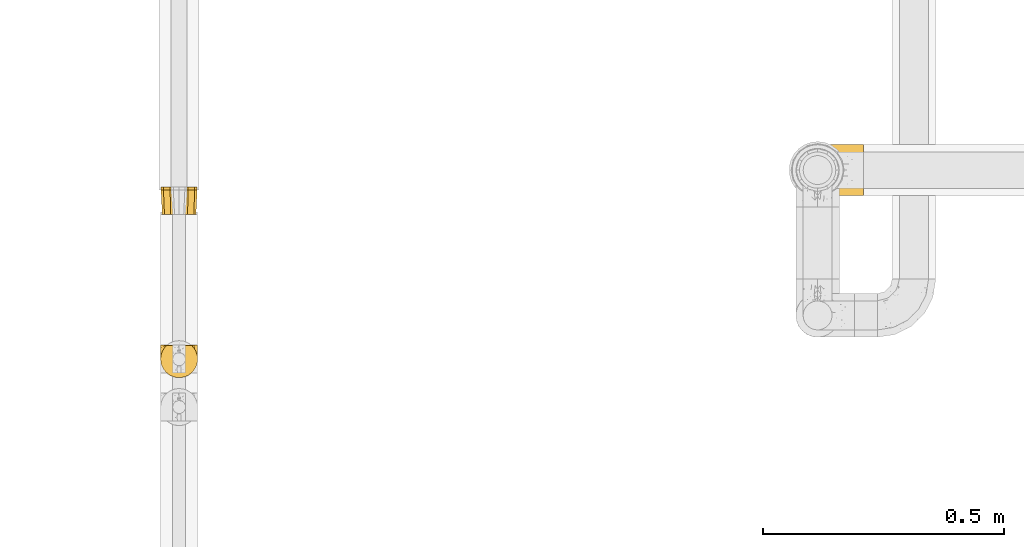
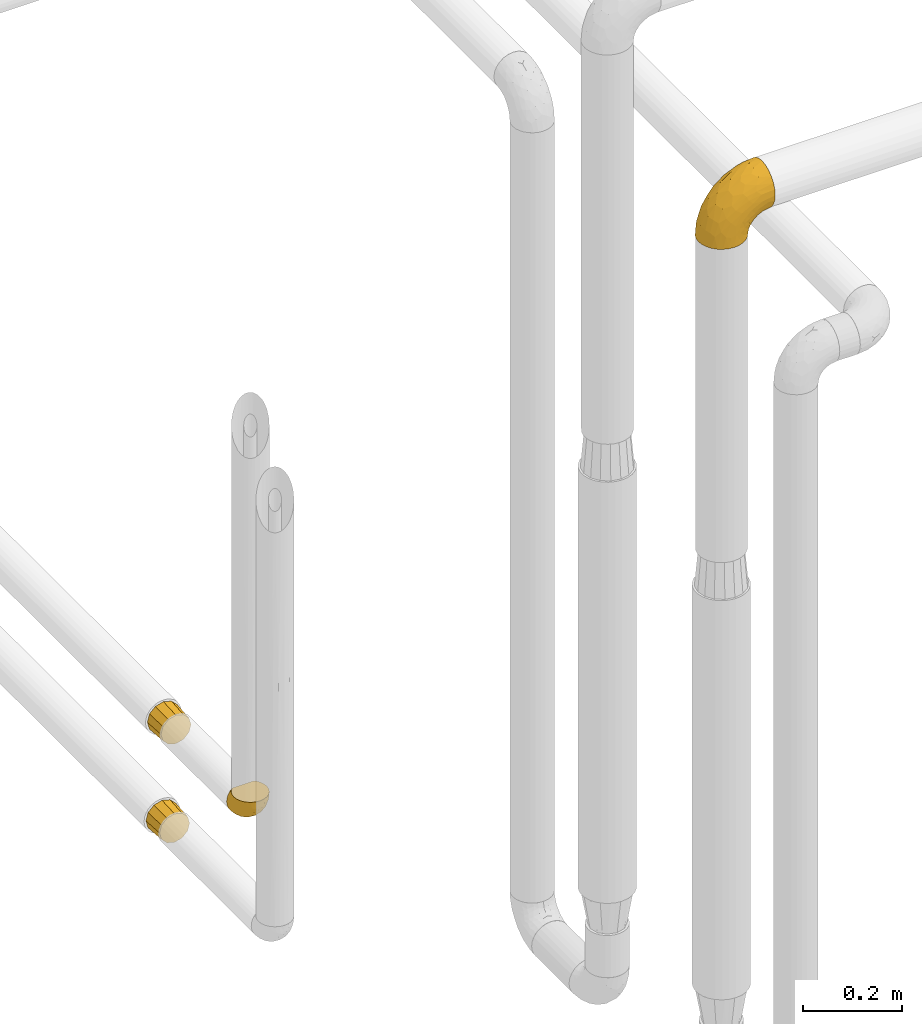
# One storey, part 106 of 827: 4 coverings.
"""IFC2X3 building model written with IfcOpenShell, lengths in millimetres."""

from ifc_helpers import new_model, entity, si_unit, converted_unit, derived_unit, direction, frame, origin, place, context, subcontext, project, spatial, faceted_brep, element, save


model = new_model("IFC2X3")

# Units and contexts
model_context = context("Model", 3, precision=0.01, world=origin(), true_north=direction((6.12303176911189e-17, 1.0)))
body_context = subcontext(model_context, "Body", "Model", "MODEL_VIEW")
ifc_project = project(units=[si_unit("LENGTHUNIT", "METRE", prefix="MILLI"), si_unit("AREAUNIT", "SQUARE_METRE"), si_unit("VOLUMEUNIT", "CUBIC_METRE"), converted_unit("PLANEANGLEUNIT", "DEGREE", entity("IfcRatioMeasure", 0.0174532925199433), si_unit("PLANEANGLEUNIT", "RADIAN"), dimensions=[0, 0, 0, 0, 0, 0, 0]), si_unit("MASSUNIT", "GRAM", prefix="KILO"), derived_unit("MASSDENSITYUNIT", [(si_unit("MASSUNIT", "GRAM", prefix="KILO"), 1), (si_unit("LENGTHUNIT", "METRE"), -3)]), derived_unit("MOMENTOFINERTIAUNIT", [(si_unit("LENGTHUNIT", "METRE"), 4)]), si_unit("TIMEUNIT", "SECOND"), si_unit("FREQUENCYUNIT", "HERTZ"), si_unit("THERMODYNAMICTEMPERATUREUNIT", "DEGREE_CELSIUS"), derived_unit("THERMALTRANSMITTANCEUNIT", [(si_unit("MASSUNIT", "GRAM", prefix="KILO"), 1), (si_unit("THERMODYNAMICTEMPERATUREUNIT", "KELVIN"), -1), (si_unit("TIMEUNIT", "SECOND"), -3)]), derived_unit("VOLUMETRICFLOWRATEUNIT", [(si_unit("LENGTHUNIT", "METRE"), 3), (si_unit("TIMEUNIT", "SECOND"), -1)]), derived_unit("MASSFLOWRATEUNIT", [(si_unit("MASSUNIT", "GRAM", prefix="KILO"), 1), (si_unit("TIMEUNIT", "SECOND"), -1)]), derived_unit("ROTATIONALFREQUENCYUNIT", [(si_unit("TIMEUNIT", "SECOND"), -1)]), si_unit("ELECTRICCURRENTUNIT", "AMPERE"), si_unit("ELECTRICVOLTAGEUNIT", "VOLT"), si_unit("POWERUNIT", "WATT"), si_unit("FORCEUNIT", "NEWTON", prefix="KILO"), si_unit("ILLUMINANCEUNIT", "LUX"), si_unit("LUMINOUSFLUXUNIT", "LUMEN"), si_unit("LUMINOUSINTENSITYUNIT", "CANDELA"), derived_unit("USERDEFINED", [(si_unit("MASSUNIT", "GRAM", prefix="KILO"), -1), (si_unit("LENGTHUNIT", "METRE"), -2), (si_unit("TIMEUNIT", "SECOND"), 3), (si_unit("LUMINOUSFLUXUNIT", "LUMEN"), 1)]), derived_unit("LINEARVELOCITYUNIT", [(si_unit("LENGTHUNIT", "METRE"), 1), (si_unit("TIMEUNIT", "SECOND"), -1)]), si_unit("PRESSUREUNIT", "PASCAL"), derived_unit("USERDEFINED", [(si_unit("LENGTHUNIT", "METRE"), -2), (si_unit("MASSUNIT", "GRAM", prefix="KILO"), 1), (si_unit("TIMEUNIT", "SECOND"), -2)]), derived_unit("LINEARFORCEUNIT", [(si_unit("MASSUNIT", "GRAM", prefix="KILO"), 1), (si_unit("LENGTHUNIT", "METRE"), 1), (si_unit("TIMEUNIT", "SECOND"), -2), (si_unit("LENGTHUNIT", "METRE"), -1)]), derived_unit("PLANARFORCEUNIT", [(si_unit("MASSUNIT", "GRAM", prefix="KILO"), 1), (si_unit("LENGTHUNIT", "METRE"), 1), (si_unit("TIMEUNIT", "SECOND"), -2), (si_unit("LENGTHUNIT", "METRE"), -2)])], contexts=[model_context])

# Site, building, storey
site_placement = place(None, origin())
site = spatial("IfcSite", under=ifc_project, at=site_placement, CompositionType="ELEMENT")
building_placement = place(site_placement, origin())
building = spatial("IfcBuilding", under=site, at=building_placement, CompositionType="ELEMENT")
storey_placement = place(building_placement, frame((0.0, 0.0, 28200.0)))
storey = spatial("IfcBuildingStorey", under=building, at=storey_placement, Name="08", CompositionType="ELEMENT", Elevation=28200.0)

# Coverings
covering_1_placement = place(storey_placement, frame((19737.17, 10713.25, 1519.07)))
element("IfcCovering", 1, at=covering_1_placement, inside=storey, Name=":ADSK_", ObjectType=":ADSK_", PredefinedType="INSULATION", context=body_context, shape_type="Brep", body=[
    faceted_brep([(57.85, 51.0, 6.62), (51.96, 51.0, 5.04), (45.53, 51.0, 3.32), (39.1, 51.0, 1.6), (32.66, 51.0, 3.32), (26.23, 51.0, 5.04), (20.35, 51.0, 6.62), (13.48, 51.0, 13.48), (6.62, 51.0, 20.35), (5.04, 51.0, 26.23), (3.32, 51.0, 32.66), (1.6, 51.0, 39.1), (3.32, 51.0, 45.53), (5.04, 51.0, 51.96), (6.62, 51.0, 57.85), (13.48, 51.0, 64.71), (20.35, 51.0, 71.57), (26.23, 51.0, 73.15), (32.66, 51.0, 74.87), (39.1, 51.0, 76.6), (45.53, 51.0, 74.87), (51.96, 51.0, 73.15), (57.85, 51.0, 71.57), (64.71, 51.0, 64.71), (71.57, 51.0, 57.85), (73.15, 51.0, 51.96), (74.87, 51.0, 45.53), (76.6, 51.0, 39.1), (74.87, 51.0, 32.66), (73.15, 51.0, 26.23), (71.57, 51.0, 20.35), (64.71, 51.0, 13.48), (21.6, 0.0, 69.41), (15.19, 0.0, 63.0), (8.78, 0.0, 56.6), (6.44, 0.0, 47.85), (4.1, 0.0, 39.1), (6.44, 0.0, 30.35), (8.78, 0.0, 21.6), (15.19, 0.0, 15.19), (21.6, 0.0, 8.78), (30.35, 0.0, 6.44), (39.1, 0.0, 4.1), (47.85, 0.0, 6.44), (56.6, 0.0, 8.78), (63.0, 0.0, 15.19), (69.41, 0.0, 21.6), (71.75, 0.0, 30.35), (74.1, 0.0, 39.1), (71.75, 0.0, 47.85), (69.41, 0.0, 56.6), (63.0, 0.0, 63.0), (56.6, 0.0, 69.41), (47.85, 0.0, 71.75), (39.1, 0.0, 74.1), (30.35, 0.0, 71.75)], [[[0, 1, 2, 3, 4, 5, 6, 7, 8, 9, 10, 11, 12, 13, 14, 15, 16, 17, 18, 19, 20, 21, 22, 23, 24, 25, 26, 27, 28, 29, 30, 31]], [[32, 33, 34, 35, 36, 37, 38, 39, 40, 41, 42, 43, 44, 45, 46, 47, 48, 49, 50, 51, 52, 53, 54, 55]], [[46, 30, 29, 28, 27, 48, 47]], [[42, 3, 2, 1, 0, 44, 43]], [[31, 30, 46, 45, 44, 0]], [[40, 6, 5, 4, 3, 42, 41]], [[36, 11, 10, 9, 8, 38, 37]], [[7, 6, 40, 39, 38, 8]], [[34, 14, 13, 12, 11, 36, 35]], [[54, 19, 18, 17, 16, 32, 55]], [[15, 14, 34, 33, 32, 16]], [[52, 22, 21, 20, 19, 54, 53]], [[48, 27, 26, 25, 24, 50, 49]], [[23, 22, 52, 51, 50, 24]]]),
])
covering_2_placement = place(storey_placement, frame((19736.22, 10367.54, 1764.53)))
element("IfcCovering", 2, at=covering_2_placement, inside=storey, Name=":ADSK_", ObjectType=":ADSK_", PredefinedType="INSULATION", context=body_context, shape_type="Brep", body=[
    faceted_brep([(74.68, 69.15, 23.36), (70.1, 69.15, 16.07), (64.01, 69.15, 9.98), (56.72, 69.15, 5.4), (48.6, 69.15, 2.56), (40.05, 69.15, 1.6), (31.49, 69.15, 2.56), (23.36, 69.15, 5.41), (16.07, 69.15, 9.99), (9.98, 69.15, 16.08), (5.4, 69.15, 23.37), (2.56, 69.15, 31.49), (1.6, 69.15, 40.05), (2.46, 69.15, 48.15), (5.01, 69.15, 55.88), (9.13, 69.15, 62.9), (14.62, 69.15, 68.89), (16.82, 69.15, 68.89), (18.56, 69.15, 68.89), (20.52, 69.15, 68.89), (22.49, 69.15, 68.89), (24.46, 69.15, 68.89), (26.42, 69.15, 68.89), (28.39, 69.15, 68.89), (30.36, 69.15, 68.89), (32.55, 69.15, 68.89), (34.75, 69.15, 68.89), (36.94, 69.15, 68.89), (39.13, 69.15, 68.89), (41.33, 69.15, 68.89), (43.52, 69.15, 68.89), (45.72, 69.15, 68.89), (47.91, 69.15, 68.89), (50.11, 69.15, 68.89), (52.3, 69.15, 68.89), (54.49, 69.15, 68.89), (56.69, 69.15, 68.89), (58.88, 69.15, 68.89), (61.08, 69.15, 68.89), (63.27, 69.15, 68.89), (65.47, 69.15, 68.89), (70.97, 69.15, 62.89), (75.09, 69.15, 55.86), (77.64, 69.15, 48.13), (78.5, 69.15, 40.05), (77.53, 69.15, 31.49), (14.62, 68.89, 69.15), (9.12, 62.89, 69.15), (5.0, 55.87, 69.15), (2.46, 48.14, 69.15), (1.6, 40.05, 69.15), (2.91, 30.09, 69.15), (6.75, 20.82, 69.15), (12.86, 12.86, 69.15), (20.82, 6.75, 69.15), (30.09, 2.91, 69.15), (40.05, 1.6, 69.15), (50.0, 2.91, 69.15), (59.27, 6.75, 69.15), (67.23, 12.86, 69.15), (73.34, 20.82, 69.15), (77.19, 30.09, 69.15), (78.5, 40.05, 69.15), (77.63, 48.14, 69.15), (75.09, 55.87, 69.15), (70.97, 62.89, 69.15), (65.47, 68.89, 69.15), (63.27, 68.89, 69.15), (62.29, 68.89, 69.15), (60.7, 68.89, 69.15), (59.11, 68.89, 69.15), (57.52, 68.89, 69.15), (55.93, 68.89, 69.15), (54.34, 68.89, 69.15), (52.76, 68.89, 69.15), (51.17, 68.89, 69.15), (49.58, 68.89, 69.15), (47.99, 68.89, 69.15), (46.4, 68.89, 69.15), (44.81, 68.89, 69.15), (43.22, 68.89, 69.15), (41.63, 68.89, 69.15), (40.05, 68.89, 69.15), (38.46, 68.89, 69.15), (36.87, 68.89, 69.15), (35.28, 68.89, 69.15), (33.69, 68.89, 69.15), (32.1, 68.89, 69.15), (30.51, 68.89, 69.15), (28.92, 68.89, 69.15), (27.33, 68.89, 69.15), (25.37, 68.89, 69.15), (23.4, 68.89, 69.15), (21.21, 68.89, 69.15), (19.01, 68.89, 69.15), (16.82, 68.89, 69.15), (42.32, 68.97, 68.96), (44.02, 68.96, 68.97), (47.13, 68.97, 68.97), (48.74, 68.97, 68.97), (23.57, 68.98, 68.95), (25.13, 68.97, 68.96), (61.34, 68.96, 68.98), (22.02, 68.96, 68.97), (29.72, 68.96, 68.97), (56.73, 68.96, 68.98), (55.14, 68.96, 68.97), (37.66, 68.96, 68.97), (64.12, 69.0, 68.94), (28.13, 68.96, 68.98), (26.62, 68.96, 68.98), (31.46, 68.97, 68.96), (16.16, 68.96, 68.97), (39.16, 68.96, 68.98), (50.37, 68.96, 68.98), (17.69, 68.97, 68.97), (19.17, 68.97, 68.96), (62.78, 68.97, 68.97), (58.35, 68.96, 68.97), (45.53, 68.96, 68.98), (59.91, 68.97, 68.96), (65.47, 68.97, 68.97), (65.47, 69.02, 68.94), (65.47, 69.08, 68.92), (14.62, 68.97, 68.97), (14.62, 68.94, 69.02), (14.62, 68.92, 69.08), (20.59, 68.96, 68.98), (32.99, 68.96, 68.97), (34.48, 68.95, 68.98), (51.91, 68.96, 68.97), (65.47, 68.92, 69.08), (65.47, 68.94, 69.02), (53.48, 68.98, 68.96), (14.62, 69.08, 68.92), (14.62, 69.02, 68.94), (40.77, 68.96, 68.97), (35.97, 68.97, 68.96), (7.84, 61.33, 67.02), (3.53, 53.1, 63.33), (8.32, 63.33, 64.61), (2.19, 55.53, 51.4), (3.53, 63.33, 53.1), (1.6, 54.6, 43.94), (1.6, 41.99, 61.87), (4.57, 57.07, 61.54), (3.96, 57.95, 57.95), (2.28, 51.56, 56.12), (1.6, 41.58, 63.4), (7.69, 61.7, 65.41), (8.32, 65.0, 63.04), (7.84, 67.02, 61.33), (1.6, 61.87, 41.99), (1.6, 49.27, 49.27), (1.6, 43.94, 54.6), (4.34, 61.21, 56.6), (1.6, 63.4, 41.58), (29.63, 33.11, 13.72), (27.34, 52.82, 5.82), (40.05, 43.3, 6.74), (2.39, 33.73, 58.82), (2.43, 36.52, 51.58), (9.07, 24.87, 42.09), (16.64, 14.17, 46.12), (9.54, 18.43, 55.56), (4.52, 28.67, 52.38), (4.52, 26.0, 61.54), (7.49, 49.25, 23.76), (7.49, 59.72, 20.5), (12.85, 55.1, 14.64), (2.35, 44.72, 41.77), (22.66, 34.15, 16.28), (32.9, 5.25, 49.4), (25.33, 6.75, 52.34), (40.05, 55.54, 4.3), (16.64, 10.47, 58.67), (19.99, 25.49, 25.26), (16.37, 35.53, 20.17), (3.26, 48.22, 34.7), (3.75, 58.71, 28.67), (19.58, 57.42, 8.62), (7.5, 34.84, 33.37), (4.04, 36.87, 41.35), (13.94, 45.01, 17.15), (19.58, 44.4, 12.68), (28.21, 23.96, 21.47), (24.75, 11.2, 41.11), (31.42, 10.56, 37.53), (26.2, 16.81, 30.64), (33.36, 17.38, 26.66), (40.05, 21.38, 21.38), (40.05, 32.34, 14.06), (40.05, 4.3, 55.54), (16.14, 20.65, 35.17), (12.85, 29.66, 29.04), (10.47, 39.6, 24.34), (6.49, 42.55, 29.33), (40.05, 6.74, 43.3), (40.05, 14.06, 32.34), (75.57, 26.84, 57.75), (47.37, 5.28, 49.41), (52.91, 18.52, 27.85), (50.46, 33.13, 13.7), (67.23, 55.1, 14.63), (60.5, 57.43, 8.61), (70.55, 20.72, 48.85), (63.45, 11.46, 54.13), (62.61, 17.69, 37.84), (72.6, 49.26, 23.75), (72.6, 59.73, 20.49), (76.34, 58.71, 28.66), (59.34, 29.72, 20.83), (77.76, 35.35, 55.15), (78.5, 43.94, 54.6), (78.5, 41.99, 61.87), (78.5, 63.4, 41.58), (53.16, 4.93, 57.58), (70.55, 17.46, 59.91), (48.88, 10.94, 36.94), (54.76, 8.92, 45.72), (52.74, 52.83, 5.82), (71.93, 29.34, 37.91), (75.79, 30.26, 50.18), (60.5, 44.4, 12.67), (77.86, 39.06, 49.29), (77.64, 43.06, 42.64), (78.5, 54.6, 43.94), (78.5, 49.27, 49.27), (67.23, 42.69, 19.45), (76.82, 48.2, 34.7), (78.5, 61.87, 41.99), (77.8, 33.44, 62.29), (67.23, 29.67, 29.01), (73.2, 38.5, 31.47), (67.66, 23.35, 37.18), (75.99, 34.97, 43.45), (76.57, 53.1, 63.33), (73.21, 59.68, 67.23), (71.93, 62.19, 66.07), (71.07, 64.11, 65.22), (75.09, 57.97, 61.99), (76.13, 57.95, 57.95), (76.57, 63.33, 53.09), (77.69, 51.77, 56.84), (72.26, 67.02, 61.33), (71.77, 64.98, 63.06), (77.9, 55.53, 51.41), (75.75, 61.22, 56.61)], [[[0, 1, 2, 3, 4, 5, 6, 7, 8, 9, 10, 11, 12, 13, 14, 15, 16, 17, 18, 19, 20, 21, 22, 23, 24, 25, 26, 27, 28, 29, 30, 31, 32, 33, 34, 35, 36, 37, 38, 39, 40, 41, 42, 43, 44, 45]], [[46, 47, 48, 49, 50, 51, 52, 53, 54, 55, 56, 57, 58, 59, 60, 61, 62, 63, 64, 65, 66, 67, 68, 69, 70, 71, 72, 73, 74, 75, 76, 77, 78, 79, 80, 81, 82, 83, 84, 85, 86, 87, 88, 89, 90, 91, 92, 93, 94, 95]], [[96, 97, 30]], [[98, 77, 99]], [[100, 101, 21]], [[69, 68, 102]], [[20, 19, 103]], [[24, 23, 104]], [[20, 103, 100]], [[72, 105, 106]], [[84, 83, 107]], [[89, 88, 104]], [[108, 67, 66]], [[109, 110, 90]], [[111, 25, 24]], [[112, 17, 16]], [[82, 113, 83]], [[109, 23, 22]], [[114, 76, 75]], [[105, 36, 106]], [[104, 111, 24]], [[18, 115, 116]], [[97, 96, 80]], [[67, 108, 117]], [[105, 71, 118]], [[31, 97, 119]], [[102, 120, 69]], [[108, 121, 122, 123, 40]], [[112, 95, 115]], [[17, 115, 18]], [[94, 116, 115]], [[117, 68, 67]], [[38, 117, 39]], [[112, 124, 125, 126, 46]], [[17, 112, 115]], [[70, 120, 118]], [[39, 117, 108]], [[120, 38, 37]], [[120, 37, 118]], [[120, 70, 69]], [[116, 94, 127]], [[128, 86, 129]], [[117, 38, 102]], [[74, 130, 75]], [[99, 33, 32]], [[115, 95, 94]], [[39, 108, 40]], [[108, 66, 131, 132, 121]], [[105, 72, 71]], [[118, 37, 36]], [[71, 70, 118]], [[35, 106, 36]], [[36, 105, 118]], [[35, 133, 106]], [[74, 73, 133]], [[106, 133, 73]], [[99, 114, 33]], [[133, 35, 34]], [[73, 72, 106]], [[95, 112, 46]], [[112, 16, 134, 135, 124]], [[130, 114, 75]], [[99, 76, 114]], [[114, 130, 33]], [[34, 33, 130]], [[78, 77, 98]], [[98, 119, 78]], [[130, 133, 34]], [[133, 130, 74]], [[79, 97, 80]], [[98, 99, 32]], [[98, 32, 31]], [[77, 76, 99]], [[97, 79, 119]], [[136, 96, 29]], [[30, 97, 31]], [[136, 29, 28]], [[81, 80, 96]], [[29, 96, 30]], [[31, 119, 98]], [[119, 79, 78]], [[96, 136, 81]], [[82, 81, 136]], [[113, 107, 83]], [[84, 107, 137]], [[107, 27, 137]], [[113, 28, 107]], [[27, 107, 28]], [[85, 84, 137]], [[137, 27, 26]], [[113, 136, 28]], [[136, 113, 82]], [[109, 89, 104]], [[86, 85, 129]], [[89, 109, 90]], [[111, 87, 128]], [[26, 129, 137]], [[88, 111, 104]], [[25, 111, 128]], [[22, 110, 109]], [[23, 109, 104]], [[110, 91, 90]], [[100, 92, 101]], [[110, 22, 101]], [[91, 110, 101]], [[116, 19, 18]], [[111, 88, 87]], [[127, 103, 19]], [[25, 128, 26]], [[86, 128, 87]], [[128, 129, 26]], [[137, 129, 85]], [[120, 102, 38]], [[117, 102, 68]], [[91, 101, 92]], [[21, 101, 22]], [[93, 92, 103]], [[100, 21, 20]], [[100, 103, 92]], [[127, 93, 103]], [[93, 127, 94]], [[116, 127, 19]], [[126, 138, 47]], [[48, 138, 139]], [[140, 125, 124]], [[141, 142, 143]], [[144, 49, 139]], [[145, 140, 146]], [[48, 139, 49]], [[139, 145, 147]], [[49, 144, 148, 50]], [[126, 125, 149]], [[14, 13, 142]], [[150, 146, 140]], [[149, 140, 145]], [[151, 150, 135]], [[151, 14, 142]], [[16, 15, 134]], [[13, 152, 142]], [[124, 150, 140]], [[141, 143, 153]], [[14, 151, 15]], [[15, 151, 134]], [[47, 46, 126]], [[139, 154, 144]], [[138, 48, 47]], [[125, 140, 149]], [[135, 134, 151]], [[146, 155, 141]], [[145, 146, 147]], [[149, 139, 138]], [[147, 153, 154]], [[147, 146, 141]], [[139, 147, 154]], [[139, 149, 145]], [[149, 138, 126]], [[147, 141, 153]], [[146, 150, 155]], [[151, 155, 150]], [[142, 141, 155]], [[13, 12, 156, 152]], [[152, 143, 142]], [[151, 142, 155]], [[150, 124, 135]], [[157, 158, 159]], [[160, 154, 161]], [[162, 163, 164]], [[165, 166, 160]], [[167, 168, 169]], [[153, 170, 161]], [[156, 12, 11]], [[158, 157, 171]], [[172, 55, 173]], [[158, 6, 174]], [[175, 54, 53]], [[52, 166, 164]], [[52, 164, 53]], [[54, 175, 173]], [[166, 52, 51]], [[176, 177, 171]], [[178, 143, 179]], [[156, 11, 179]], [[8, 7, 180]], [[169, 9, 8]], [[179, 143, 152, 156]], [[179, 11, 10]], [[168, 179, 10]], [[181, 162, 182]], [[179, 167, 178]], [[183, 184, 177]], [[183, 169, 184]], [[176, 171, 185]], [[172, 186, 187]], [[158, 7, 6]], [[159, 158, 174]], [[184, 180, 158]], [[54, 173, 55]], [[180, 169, 8]], [[188, 189, 187]], [[9, 168, 10]], [[186, 188, 187]], [[190, 157, 159, 191]], [[55, 172, 192]], [[176, 193, 194]], [[161, 170, 182]], [[162, 164, 165]], [[175, 164, 163]], [[51, 50, 148]], [[167, 195, 196]], [[178, 182, 170]], [[6, 5, 174]], [[158, 180, 7]], [[169, 180, 184]], [[169, 168, 9]], [[179, 168, 167]], [[182, 162, 165]], [[162, 194, 193]], [[161, 165, 160]], [[195, 181, 196]], [[192, 172, 197]], [[192, 56, 55]], [[189, 190, 198]], [[198, 197, 187]], [[172, 187, 197]], [[185, 189, 188]], [[198, 187, 189]], [[186, 172, 173]], [[173, 163, 186]], [[193, 186, 163]], [[176, 185, 188]], [[185, 157, 190]], [[188, 186, 193]], [[177, 176, 194]], [[188, 193, 176]], [[162, 193, 163]], [[195, 177, 194]], [[171, 177, 184]], [[181, 195, 194]], [[183, 167, 169]], [[162, 181, 194]], [[196, 182, 178]], [[158, 171, 184]], [[171, 157, 185]], [[177, 195, 183]], [[167, 183, 195]], [[182, 196, 181]], [[178, 170, 143]], [[178, 167, 196]], [[164, 175, 53]], [[173, 175, 163]], [[160, 51, 148]], [[164, 166, 165]], [[51, 160, 166]], [[160, 148, 144, 154]], [[153, 161, 154]], [[182, 165, 161]], [[190, 189, 185]], [[143, 170, 153]], [[60, 199, 61]], [[197, 200, 192]], [[201, 190, 202]], [[200, 57, 192]], [[203, 204, 2]], [[205, 206, 207]], [[208, 209, 210]], [[211, 207, 201]], [[212, 213, 214]], [[45, 215, 210]], [[216, 206, 58]], [[45, 44, 215]], [[59, 217, 60]], [[60, 217, 199]], [[0, 45, 210]], [[218, 201, 219]], [[202, 159, 220]], [[205, 221, 222]], [[223, 204, 203]], [[1, 203, 2]], [[57, 200, 216]], [[220, 3, 204]], [[220, 174, 4]], [[1, 0, 209]], [[212, 224, 213]], [[225, 226, 227]], [[228, 223, 203]], [[208, 210, 229]], [[210, 226, 229]], [[3, 220, 4]], [[58, 206, 59]], [[209, 203, 1]], [[202, 220, 223]], [[228, 203, 208]], [[202, 211, 201]], [[3, 2, 204]], [[202, 190, 191, 159]], [[210, 215, 230, 226]], [[199, 212, 231]], [[232, 233, 221]], [[233, 208, 229]], [[207, 206, 219]], [[217, 206, 205]], [[227, 224, 225]], [[233, 232, 228]], [[201, 207, 219]], [[234, 232, 221]], [[218, 219, 200]], [[202, 223, 211]], [[174, 220, 159]], [[174, 5, 4]], [[61, 231, 62]], [[220, 204, 223]], [[210, 209, 0]], [[203, 209, 208]], [[225, 233, 229]], [[224, 227, 213]], [[221, 233, 235]], [[57, 56, 192]], [[198, 218, 197]], [[200, 219, 216]], [[201, 198, 190]], [[197, 218, 200]], [[198, 201, 218]], [[206, 216, 219]], [[58, 57, 216]], [[231, 212, 214]], [[222, 212, 199]], [[228, 211, 223]], [[207, 211, 232]], [[62, 231, 214]], [[199, 231, 61]], [[233, 228, 208]], [[211, 228, 232]], [[222, 221, 235]], [[234, 205, 207]], [[206, 217, 59]], [[199, 217, 205]], [[205, 222, 199]], [[224, 222, 235]], [[222, 224, 212]], [[224, 235, 225]], [[233, 225, 235]], [[226, 225, 229]], [[205, 234, 221]], [[207, 232, 234]], [[63, 214, 236]], [[214, 213, 236]], [[214, 63, 62]], [[237, 236, 238]], [[238, 132, 131]], [[236, 237, 64]], [[239, 240, 241]], [[63, 236, 64]], [[131, 66, 65]], [[237, 131, 65]], [[242, 230, 43]], [[237, 65, 64]], [[239, 121, 132]], [[42, 242, 43]], [[241, 240, 243]], [[41, 123, 244]], [[43, 230, 215, 44]], [[244, 122, 245]], [[227, 246, 243]], [[245, 241, 247]], [[121, 239, 245]], [[41, 40, 123]], [[132, 238, 239]], [[244, 42, 41]], [[131, 237, 238]], [[240, 239, 238]], [[245, 239, 241]], [[247, 241, 246]], [[247, 244, 245]], [[238, 236, 240]], [[243, 236, 213]], [[236, 243, 240]], [[246, 241, 243]], [[243, 213, 227]], [[226, 242, 246]], [[227, 226, 246]], [[246, 242, 247]], [[244, 247, 242]], [[242, 226, 230]], [[42, 244, 242]], [[122, 244, 123]], [[122, 121, 245]]]),
])
covering_3_placement = place(storey_placement, frame((19737.17, 10707.58, 1765.48)))
element("IfcCovering", 3, at=covering_3_placement, inside=storey, Name=":ADSK_", ObjectType=":ADSK_", PredefinedType="INSULATION", context=body_context, shape_type="Brep", body=[
    faceted_brep([(57.85, 51.0, 6.62), (51.96, 51.0, 5.04), (45.53, 51.0, 3.32), (39.1, 51.0, 1.6), (32.66, 51.0, 3.32), (26.23, 51.0, 5.04), (20.35, 51.0, 6.62), (13.48, 51.0, 13.48), (6.62, 51.0, 20.35), (5.04, 51.0, 26.23), (3.32, 51.0, 32.66), (1.6, 51.0, 39.1), (3.32, 51.0, 45.53), (5.04, 51.0, 51.96), (6.62, 51.0, 57.85), (13.48, 51.0, 64.71), (20.35, 51.0, 71.57), (26.23, 51.0, 73.15), (32.66, 51.0, 74.87), (39.1, 51.0, 76.6), (45.53, 51.0, 74.87), (51.96, 51.0, 73.15), (57.85, 51.0, 71.57), (64.71, 51.0, 64.71), (71.57, 51.0, 57.85), (73.15, 51.0, 51.96), (74.87, 51.0, 45.53), (76.6, 51.0, 39.1), (74.87, 51.0, 32.66), (73.15, 51.0, 26.23), (71.57, 51.0, 20.35), (64.71, 51.0, 13.48), (21.6, 0.0, 69.41), (15.19, 0.0, 63.0), (8.78, 0.0, 56.6), (6.44, 0.0, 47.85), (4.1, 0.0, 39.1), (6.44, 0.0, 30.35), (8.78, 0.0, 21.6), (15.19, 0.0, 15.19), (21.6, 0.0, 8.78), (30.35, 0.0, 6.44), (39.1, 0.0, 4.1), (47.85, 0.0, 6.44), (56.6, 0.0, 8.78), (63.0, 0.0, 15.19), (69.41, 0.0, 21.6), (71.75, 0.0, 30.35), (74.1, 0.0, 39.1), (71.75, 0.0, 47.85), (69.41, 0.0, 56.6), (63.0, 0.0, 63.0), (56.6, 0.0, 69.41), (47.85, 0.0, 71.75), (39.1, 0.0, 74.1), (30.35, 0.0, 71.75)], [[[0, 1, 2, 3, 4, 5, 6, 7, 8, 9, 10, 11, 12, 13, 14, 15, 16, 17, 18, 19, 20, 21, 22, 23, 24, 25, 26, 27, 28, 29, 30, 31]], [[32, 33, 34, 35, 36, 37, 38, 39, 40, 41, 42, 43, 44, 45, 46, 47, 48, 49, 50, 51, 52, 53, 54, 55]], [[46, 30, 29, 28, 27, 48, 47]], [[42, 3, 2, 1, 0, 44, 43]], [[31, 30, 46, 45, 44, 0]], [[40, 6, 5, 4, 3, 42, 41]], [[36, 11, 10, 9, 8, 38, 37]], [[7, 6, 40, 39, 38, 8]], [[34, 14, 13, 12, 11, 36, 35]], [[54, 19, 18, 17, 16, 32, 55]], [[15, 14, 34, 33, 32, 16]], [[52, 22, 21, 20, 19, 54, 53]], [[48, 27, 26, 25, 24, 50, 49]], [[23, 22, 52, 51, 50, 24]]]),
])
covering_4_placement = place(storey_placement, frame((21045.65, 10745.0, 2503.4)))
element("IfcCovering", 4, at=covering_4_placement, inside=storey, Name=":ADSK_", ObjectType=":ADSK_", PredefinedType="INSULATION", context=body_context, shape_type="Brep", body=[
    faceted_brep([(2.92, 42.85, 1.6), (1.6, 54.65, 1.6), (2.93, 66.46, 1.6), (6.85, 77.67, 1.6), (13.18, 87.73, 1.6), (21.58, 96.13, 1.6), (31.64, 102.45, 1.6), (42.85, 106.37, 1.6), (54.65, 107.7, 1.6), (66.46, 106.36, 1.6), (77.67, 102.44, 1.6), (87.73, 96.11, 1.6), (96.13, 87.71, 1.6), (102.45, 77.65, 1.6), (106.37, 66.44, 1.6), (107.7, 54.65, 1.6), (106.36, 42.84, 1.6), (102.44, 31.62, 1.6), (96.11, 21.56, 1.6), (87.71, 13.16, 1.6), (77.65, 6.84, 1.6), (66.44, 2.92, 1.6), (54.65, 1.6, 1.6), (42.84, 2.93, 1.6), (31.62, 6.85, 1.6), (21.56, 13.18, 1.6), (13.16, 21.58, 1.6), (6.84, 31.64, 1.6), (149.65, 68.38, 45.35), (149.65, 81.17, 50.65), (149.65, 92.16, 59.08), (149.65, 100.59, 70.07), (149.65, 105.89, 82.86), (149.65, 107.7, 96.6), (149.65, 105.89, 110.33), (149.65, 100.59, 123.12), (149.65, 92.16, 134.11), (149.65, 81.17, 142.54), (149.65, 68.38, 147.84), (149.65, 54.65, 149.65), (149.65, 40.91, 147.84), (149.65, 28.12, 142.54), (149.65, 17.13, 134.11), (149.65, 8.7, 123.12), (149.65, 3.4, 110.33), (149.65, 1.6, 96.6), (149.65, 3.4, 82.86), (149.65, 8.7, 70.07), (149.65, 17.13, 59.08), (149.65, 28.12, 50.65), (149.65, 40.91, 45.35), (149.65, 54.65, 43.55), (123.27, 23.76, 137.19), (114.15, 35.87, 141.79), (92.97, 25.52, 128.89), (124.11, 45.07, 146.54), (111.33, 54.65, 144.6), (42.13, 12.57, 69.77), (56.83, 15.93, 94.41), (40.31, 24.82, 87.22), (61.55, 37.92, 117.2), (75.62, 54.65, 129.81), (44.96, 54.65, 106.28), (91.12, 5.82, 101.45), (109.83, 8.38, 115.81), (88.02, 10.19, 109.14), (119.19, 3.86, 107.65), (99.11, 2.5, 93.36), (27.97, 19.48, 59.44), (21.92, 29.7, 63.23), (12.94, 28.0, 35.59), (88.29, 35.28, 132.3), (95.35, 45.15, 138.41), (113.84, 14.54, 126.28), (6.64, 54.65, 39.91), (8.58, 38.55, 37.44), (33.39, 40.99, 90.35), (17.23, 43.24, 65.0), (61.99, 8.56, 85.4), (47.9, 2.51, 26.66), (37.72, 5.69, 29.88), (93.81, 1.6, 78.45), (107.05, 1.6, 85.2), (120.29, 1.6, 91.95), (73.26, 3.22, 77.98), (18.58, 18.7, 29.55), (29.72, 11.86, 41.42), (64.31, 24.78, 111.13), (82.84, 15.99, 114.67), (72.79, 1.6, 57.43), (83.3, 1.6, 67.94), (56.71, 1.6, 14.64), (59.29, 1.6, 30.95), (57.88, 2.5, 52.13), (66.04, 1.6, 44.19), (49.8, 5.82, 60.12), (21.43, 54.65, 75.62), (134.97, 1.6, 94.27), (108.79, 32.3, 24.59), (110.84, 25.01, 34.69), (101.53, 18.18, 31.15), (111.84, 3.03, 75.18), (119.98, 6.69, 67.55), (123.54, 3.21, 79.36), (134.54, 2.73, 84.32), (80.57, 3.93, 40.81), (69.55, 2.55, 29.93), (134.56, 7.7, 70.24), (128.67, 54.65, 37.93), (136.98, 54.65, 40.15), (133.56, 41.58, 42.1), (131.66, 17.93, 55.38), (117.75, 14.97, 52.17), (118.23, 22.2, 44.32), (110.55, 43.45, 19.85), (111.09, 54.65, 14.26), (113.32, 54.65, 22.57), (120.2, 40.37, 34.17), (105.95, 8.47, 54.85), (127.69, 29.46, 44.63), (139.88, 32.17, 47.52), (92.14, 3.39, 59.1), (93.82, 7.76, 44.11), (82.28, 2.57, 53.21), (130.86, 11.54, 62.86), (78.78, 6.21, 20.58), (67.58, 2.9, 15.79), (90.58, 11.19, 27.67), (90.23, 14.27, 13.49), (99.39, 22.4, 18.04), (105.17, 34.87, 12.44), (120.99, 54.65, 30.25), (104.59, 4.01, 66.71), (108.24, 16.42, 42.52), (131.66, 91.36, 55.38), (78.8, 103.07, 20.57), (133.57, 67.71, 42.11), (72.79, 107.7, 57.43), (82.27, 106.72, 53.22), (80.59, 105.35, 40.81), (110.55, 65.83, 19.85), (108.79, 76.97, 24.58), (120.2, 68.91, 34.16), (108.25, 92.85, 42.5), (106.06, 100.82, 54.93), (117.78, 94.28, 52.13), (90.6, 98.08, 27.66), (93.87, 101.51, 44.12), (93.81, 107.7, 78.45), (107.05, 107.7, 85.2), (111.89, 106.25, 75.17), (134.97, 107.7, 94.27), (134.54, 106.56, 84.32), (59.29, 107.7, 30.95), (66.04, 107.7, 44.19), (69.56, 106.74, 29.98), (104.56, 105.31, 66.78), (119.98, 102.6, 67.55), (134.56, 101.59, 70.24), (123.54, 106.08, 79.36), (90.25, 95.01, 13.48), (99.4, 86.87, 18.03), (110.83, 84.27, 34.66), (101.52, 91.11, 31.14), (105.18, 74.4, 12.43), (56.71, 107.7, 14.64), (139.89, 77.12, 47.52), (118.22, 87.06, 44.28), (67.6, 106.38, 15.8), (130.86, 97.75, 62.86), (83.3, 107.7, 67.94), (127.71, 79.83, 44.64), (92.12, 105.91, 59.12), (120.29, 107.7, 91.95), (92.97, 83.77, 128.89), (123.27, 85.53, 137.19), (113.84, 94.75, 126.28), (109.83, 100.91, 115.81), (124.03, 64.22, 146.53), (114.15, 73.42, 141.79), (98.04, 64.15, 139.45), (99.11, 106.79, 93.36), (47.9, 106.79, 26.67), (37.74, 103.61, 29.87), (49.8, 103.47, 60.12), (56.83, 93.36, 94.41), (42.16, 96.75, 69.76), (40.3, 84.48, 87.19), (57.88, 106.79, 52.13), (73.26, 106.07, 77.98), (119.19, 105.43, 107.65), (86.61, 73.44, 131.74), (27.99, 89.82, 59.44), (18.59, 90.61, 29.54), (21.92, 79.61, 63.2), (11.28, 81.34, 27.9), (33.39, 68.3, 90.35), (61.55, 71.37, 117.2), (29.73, 97.44, 41.39), (88.01, 99.1, 109.14), (62.08, 100.74, 85.46), (8.58, 70.76, 37.43), (82.84, 93.3, 114.67), (64.3, 84.5, 111.12), (91.12, 103.47, 101.45), (18.05, 68.73, 65.16)], [[[0, 1, 2, 3, 4, 5, 6, 7, 8, 9, 10, 11, 12, 13, 14, 15, 16, 17, 18, 19, 20, 21, 22, 23, 24, 25, 26, 27]], [[28, 29, 30, 31, 32, 33, 34, 35, 36, 37, 38, 39, 40, 41, 42, 43, 44, 45, 46, 47, 48, 49, 50, 51]], [[52, 53, 54]], [[55, 39, 56]], [[57, 58, 59]], [[60, 61, 62]], [[63, 64, 65]], [[66, 63, 67]], [[68, 69, 70]], [[53, 71, 54]], [[41, 40, 53]], [[53, 72, 71]], [[73, 42, 52]], [[42, 41, 52]], [[74, 0, 75]], [[69, 76, 77]], [[43, 73, 64]], [[45, 44, 66]], [[57, 78, 58]], [[23, 79, 80]], [[67, 81, 82, 83]], [[67, 84, 81]], [[24, 23, 80]], [[25, 85, 26]], [[86, 85, 25]], [[42, 73, 43]], [[0, 27, 75]], [[25, 24, 86]], [[70, 26, 85]], [[0, 74, 1]], [[68, 85, 86]], [[66, 64, 63]], [[60, 59, 87]], [[54, 87, 88]], [[76, 60, 62]], [[84, 89, 90, 81]], [[79, 22, 91, 92]], [[77, 74, 75]], [[93, 92, 94, 89]], [[80, 86, 24]], [[40, 55, 53]], [[76, 59, 60]], [[93, 84, 95]], [[76, 62, 96]], [[55, 72, 53]], [[70, 27, 26]], [[75, 70, 69]], [[78, 84, 63]], [[93, 79, 92]], [[95, 86, 80]], [[77, 76, 96]], [[59, 69, 68]], [[57, 68, 86]], [[68, 57, 59]], [[59, 58, 87]], [[76, 69, 59]], [[88, 87, 58]], [[87, 54, 71]], [[86, 95, 57]], [[78, 57, 95]], [[84, 78, 95]], [[78, 63, 65]], [[58, 78, 65]], [[54, 88, 73]], [[84, 93, 89]], [[79, 95, 80]], [[79, 93, 95]], [[22, 79, 23]], [[66, 83, 97, 45]], [[84, 67, 63]], [[83, 66, 67]], [[64, 44, 43]], [[64, 66, 44]], [[65, 73, 88]], [[53, 52, 41]], [[73, 52, 54]], [[73, 65, 64]], [[65, 88, 58]], [[39, 55, 40]], [[72, 55, 56]], [[56, 61, 72]], [[60, 72, 61]], [[72, 60, 71]], [[87, 71, 60]], [[27, 70, 75]], [[68, 70, 85]], [[74, 77, 96]], [[69, 77, 75]], [[98, 99, 100]], [[46, 45, 97]], [[101, 102, 103]], [[103, 104, 83]], [[105, 94, 106]], [[107, 103, 102]], [[108, 109, 51, 110]], [[111, 112, 113]], [[114, 115, 116]], [[47, 104, 107]], [[110, 117, 108]], [[49, 48, 111]], [[102, 118, 112]], [[119, 120, 111]], [[50, 49, 120]], [[121, 122, 118]], [[105, 123, 89]], [[124, 48, 107]], [[20, 19, 125]], [[121, 81, 90]], [[117, 119, 99]], [[21, 20, 126]], [[22, 21, 91]], [[105, 125, 127]], [[110, 51, 50]], [[19, 128, 125]], [[16, 15, 115]], [[129, 98, 100]], [[126, 91, 21]], [[128, 129, 127]], [[122, 123, 105]], [[114, 117, 98]], [[17, 16, 130]], [[18, 128, 19]], [[129, 18, 17]], [[125, 106, 126]], [[115, 114, 16]], [[130, 129, 17]], [[114, 98, 130]], [[117, 116, 131, 108]], [[99, 119, 113]], [[122, 121, 123]], [[92, 126, 106]], [[105, 127, 122]], [[132, 121, 118]], [[114, 130, 16]], [[129, 130, 98]], [[50, 120, 110]], [[129, 128, 18]], [[125, 128, 127]], [[125, 126, 20]], [[91, 126, 92]], [[105, 89, 94]], [[105, 106, 125]], [[94, 92, 106]], [[100, 122, 127]], [[118, 122, 133]], [[112, 118, 133]], [[132, 118, 102]], [[132, 102, 101]], [[81, 121, 132]], [[82, 103, 83]], [[132, 101, 81]], [[104, 47, 46]], [[124, 107, 102]], [[48, 47, 107]], [[113, 112, 133]], [[112, 111, 124]], [[99, 113, 133]], [[111, 113, 119]], [[99, 133, 100]], [[117, 99, 98]], [[122, 100, 133]], [[127, 129, 100]], [[103, 82, 101]], [[81, 101, 82]], [[112, 124, 102]], [[48, 124, 111]], [[104, 103, 107]], [[46, 97, 104]], [[111, 120, 49]], [[83, 104, 97]], [[110, 120, 119]], [[117, 110, 119]], [[116, 117, 114]], [[89, 123, 90]], [[90, 123, 121]], [[30, 29, 134]], [[11, 10, 135]], [[51, 109, 108, 136]], [[137, 138, 139]], [[140, 141, 142]], [[143, 144, 145]], [[146, 139, 147]], [[148, 149, 150]], [[151, 32, 152]], [[153, 154, 155]], [[156, 150, 157]], [[158, 157, 159]], [[108, 142, 136]], [[31, 158, 152]], [[160, 161, 12]], [[162, 163, 143]], [[140, 142, 116]], [[142, 141, 162]], [[14, 164, 140]], [[14, 140, 115]], [[9, 8, 165]], [[160, 12, 11]], [[141, 164, 161]], [[13, 12, 161]], [[14, 115, 15]], [[28, 166, 29]], [[135, 139, 146]], [[141, 163, 162]], [[135, 146, 160]], [[143, 167, 162]], [[29, 166, 134]], [[116, 142, 108, 131]], [[165, 153, 168]], [[10, 9, 168]], [[168, 135, 10]], [[138, 147, 139]], [[158, 169, 157]], [[14, 13, 164]], [[116, 115, 140]], [[145, 167, 143]], [[135, 160, 11]], [[168, 153, 155]], [[138, 137, 170]], [[157, 144, 156]], [[147, 144, 143]], [[161, 164, 13]], [[140, 164, 141]], [[142, 171, 136]], [[136, 171, 166]], [[161, 160, 146]], [[165, 168, 9]], [[155, 139, 135]], [[139, 154, 137]], [[168, 155, 135]], [[139, 155, 154]], [[144, 147, 172]], [[163, 147, 143]], [[156, 144, 172]], [[157, 169, 145]], [[172, 148, 156]], [[173, 159, 149]], [[159, 157, 150]], [[152, 159, 173]], [[159, 152, 158]], [[31, 30, 158]], [[169, 30, 134]], [[157, 145, 144]], [[167, 134, 171]], [[134, 167, 145]], [[171, 142, 162]], [[162, 167, 171]], [[163, 141, 161]], [[161, 146, 163]], [[147, 163, 146]], [[148, 150, 156]], [[149, 159, 150]], [[30, 169, 158]], [[145, 169, 134]], [[151, 33, 32]], [[31, 152, 32]], [[152, 173, 151]], [[28, 51, 136]], [[134, 166, 171]], [[28, 136, 166]], [[138, 170, 172]], [[147, 138, 172]], [[148, 172, 170]], [[174, 175, 176]], [[35, 34, 177]], [[178, 179, 180]], [[181, 173, 149, 148]], [[182, 183, 184]], [[185, 186, 187]], [[188, 189, 137]], [[190, 33, 151, 173]], [[191, 179, 174]], [[34, 190, 177]], [[39, 38, 178]], [[192, 193, 194]], [[4, 3, 195]], [[175, 179, 37]], [[38, 37, 179]], [[35, 176, 36]], [[196, 62, 197]], [[181, 190, 173]], [[37, 36, 175]], [[183, 6, 198]], [[189, 148, 170, 137]], [[185, 199, 200]], [[3, 2, 201]], [[202, 185, 203]], [[8, 7, 182]], [[200, 184, 186]], [[183, 7, 6]], [[181, 189, 204]], [[200, 189, 184]], [[5, 198, 6]], [[187, 203, 185]], [[195, 3, 201]], [[205, 196, 194]], [[62, 61, 197]], [[186, 198, 192]], [[180, 179, 191]], [[2, 1, 74]], [[198, 193, 192]], [[193, 5, 4]], [[194, 193, 195]], [[2, 74, 201]], [[5, 193, 198]], [[205, 74, 96]], [[188, 137, 154, 153]], [[62, 196, 96]], [[56, 178, 180]], [[198, 184, 183]], [[184, 188, 182]], [[203, 197, 191]], [[205, 194, 201]], [[187, 192, 194]], [[192, 187, 186]], [[194, 196, 187]], [[197, 187, 196]], [[197, 203, 187]], [[202, 174, 176]], [[200, 186, 185]], [[184, 198, 186]], [[199, 185, 202]], [[189, 200, 204]], [[174, 202, 203]], [[176, 177, 199]], [[189, 181, 148]], [[190, 181, 204]], [[190, 204, 177]], [[190, 34, 33]], [[188, 153, 182]], [[189, 188, 184]], [[182, 153, 165, 8]], [[183, 182, 7]], [[199, 177, 204]], [[35, 177, 176]], [[176, 175, 36]], [[179, 175, 174]], [[200, 199, 204]], [[176, 199, 202]], [[203, 191, 174]], [[180, 197, 61]], [[197, 180, 191]], [[61, 56, 180]], [[39, 178, 56]], [[38, 179, 178]], [[194, 195, 201]], [[4, 195, 193]], [[74, 205, 201]], [[96, 196, 205]]]),
])

save(model, "model.ifc")
